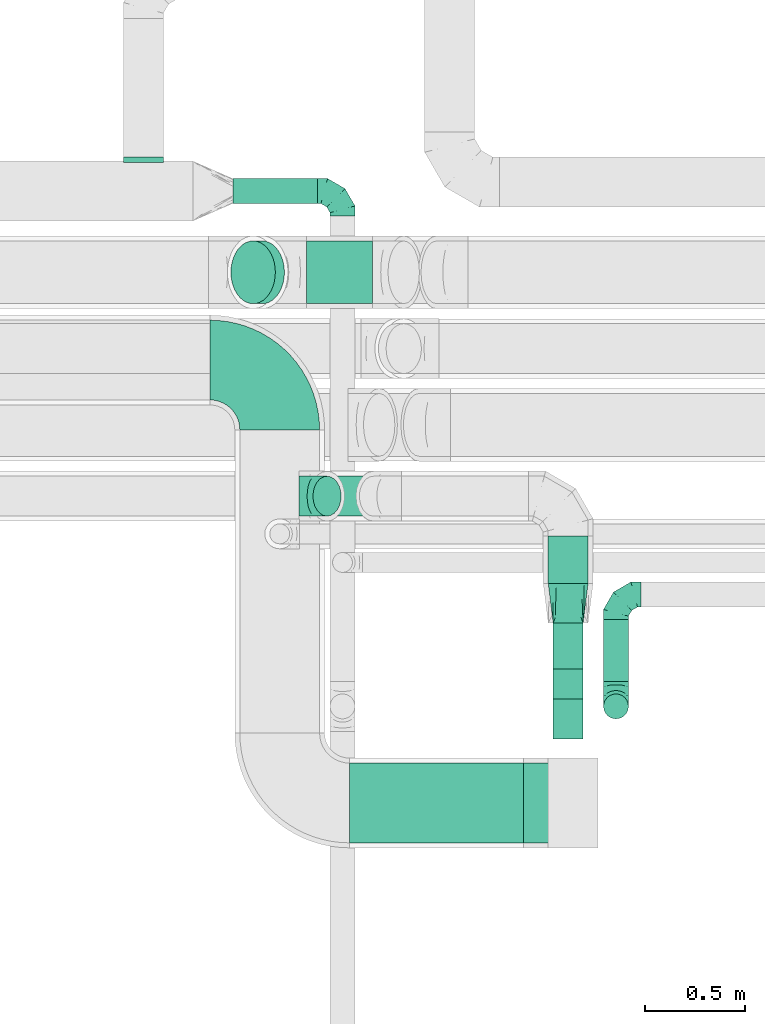
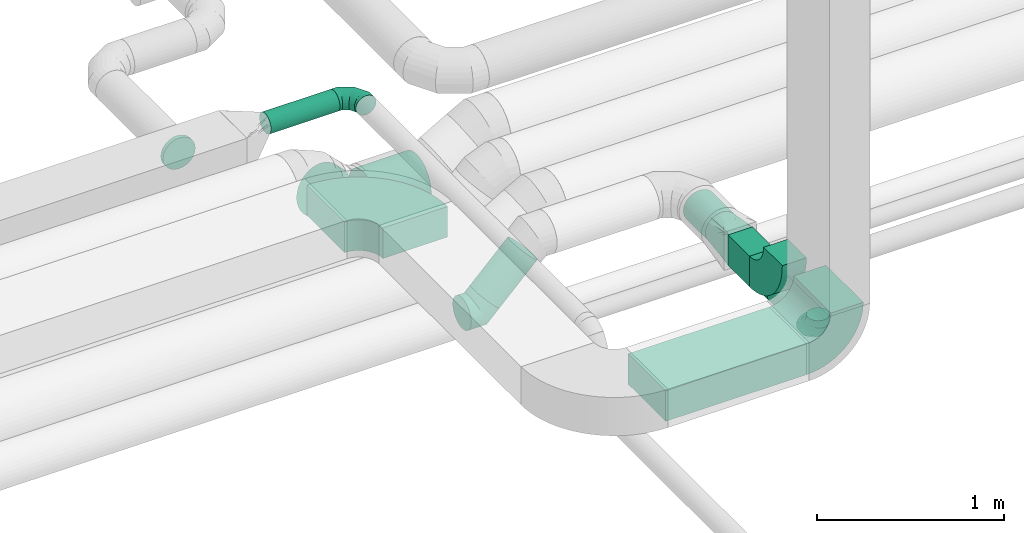
# One storey, part 63 of 92: 9 flow fittings, 8 flow segments.
"""IFC2X3 building model written with IfcOpenShell, lengths in millimetres."""

import ifcopenshell
import ifcopenshell.guid

model = None  # the IFC model being written
_history = None  # IfcOwnerHistory: only IFC2X3 demands one
_inside = {}  # id of a spatial element -> (the spatial element, [elements in it])
_under = {}  # id of a project, library or spatial element -> (it, [spatial elements below it])
_declared = {}  # id of a project -> (the project, [libraries it declares])
_typed = {}  # id of a type object -> (the type object, [elements of that type])
_made_of = {}  # id of a material, layer set ... -> (it, [elements and type objects made of it])


def new_model(schema):
    """Start an empty IFC model of exactly this schema.

    Asked for "IFC4X3", IfcOpenShell would pick the latest addendum, in which some entities
    have other attributes; the version numbers below select the first issue.
    IFC2X3 requires an IfcOwnerHistory on every rooted entity: one is made here for all.
    """
    global model, _history
    if schema == "IFC4X3":
        model = ifcopenshell.file(schema_version=(4, 3, 0, 0))
    else:
        model = ifcopenshell.file(schema=schema)
    _inside.clear()
    _under.clear()
    _declared.clear()
    _typed.clear()
    _made_of.clear()
    _history = None
    if model.schema == "IFC2X3":
        org = make("IfcOrganization", Name="unknown")
        user = make(
            "IfcPersonAndOrganization",
            ThePerson=make("IfcPerson", FamilyName="unknown"),
            TheOrganization=org,
        )
        app = make(
            "IfcApplication",
            ApplicationDeveloper=org,
            Version="unknown",
            ApplicationFullName="unknown",
            ApplicationIdentifier="unknown",
        )
        _history = make(
            "IfcOwnerHistory",
            OwningUser=user,
            OwningApplication=app,
            ChangeAction="ADDED",
            CreationDate=0,
        )
    return model


def make(cls, **values):
    """One entity of the class cls with the attributes given. An attribute that is None is left unset."""
    return model.create_entity(
        cls, **{name: value for name, value in values.items() if value is not None}
    )


def entity(cls, *values):
    """Any entity or typed value of the class cls, its attributes in the order of the schema. None: left unset."""
    e = model.create_entity(cls)
    for i, value in enumerate(values):
        if value is not None:
            e[i] = value
    return e


def rooted(cls, **values):
    """An entity with a GlobalId (a new one), such as an element, a storey or a relation."""
    return make(cls, GlobalId=ifcopenshell.guid.new(), OwnerHistory=_history, **values)


def si_unit(unit_type, name, prefix=None):
    """IfcSIUnit, for example si_unit("LENGTHUNIT", "METRE", prefix="MILLI")."""
    return make("IfcSIUnit", UnitType=unit_type, Prefix=prefix, Name=name)


def converted_unit(unit_type, name, factor, base, dimensions=None, offset=None):
    """IfcConversionBasedUnit, such as the inch: factor (a typed value) times the base unit."""
    return make(
        "IfcConversionBasedUnit"
        if offset is None
        else "IfcConversionBasedUnitWithOffset",
        ConversionOffset=offset,
        Dimensions=None
        if dimensions is None
        else entity("IfcDimensionalExponents", *dimensions),
        UnitType=unit_type,
        Name=name,
        ConversionFactor=make(
            "IfcMeasureWithUnit", ValueComponent=factor, UnitComponent=base
        ),
    )


def derived_unit(unit_type, elements):
    """IfcDerivedUnit: a product of units, each with its exponent."""
    return make(
        "IfcDerivedUnit",
        Elements=[
            make("IfcDerivedUnitElement", Unit=unit, Exponent=power)
            for unit, power in elements
        ],
        UnitType=unit_type,
    )


def assignment(units):
    """IfcUnitAssignment: the units of a project."""
    return None if units is None else make("IfcUnitAssignment", Units=units)


def point(xyz):
    """IfcCartesianPoint."""
    return None if xyz is None else make("IfcCartesianPoint", Coordinates=xyz)


def direction(xyz):
    """IfcDirection."""
    return None if xyz is None else make("IfcDirection", DirectionRatios=xyz)


def frame(location, z_axis=None, x_axis=None):
    """IfcAxis2Placement3D, a coordinate frame: its origin and axes. An axis left out is left unset."""
    return make(
        "IfcAxis2Placement3D",
        Location=point(location),
        Axis=direction(z_axis),
        RefDirection=direction(x_axis),
    )


def frame_2d(location, x_axis=None):
    """IfcAxis2Placement2D, a coordinate frame in the plane: its origin and x axis."""
    return make(
        "IfcAxis2Placement2D", Location=point(location), RefDirection=direction(x_axis)
    )


def origin():
    """The frame at (0, 0, 0) with its axes left unset."""
    return frame((0.0, 0.0, 0.0))


def origin_2d_with_axis():
    """The frame at (0, 0) in the plane with the x axis (1, 0) written out."""
    return frame_2d((0.0, 0.0), x_axis=(1.0, 0.0))


def place(relative_to, where):
    """IfcLocalPlacement: puts the frame where relative to a parent placement (None: the world)."""
    return make(
        "IfcLocalPlacement", PlacementRelTo=relative_to, RelativePlacement=where
    )


def context(
    kind, dimensions, precision=None, world=None, true_north=None, identifier=None
):
    """IfcGeometricRepresentationContext, for example the 3D "Model" context."""
    return make(
        "IfcGeometricRepresentationContext",
        ContextIdentifier=identifier,
        ContextType=kind,
        CoordinateSpaceDimension=dimensions,
        Precision=precision,
        WorldCoordinateSystem=world,
        TrueNorth=true_north,
    )


def subcontext(parent, identifier, kind, view, scale=None):
    """IfcGeometricRepresentationSubContext, for example "Body" below "Model"."""
    return make(
        "IfcGeometricRepresentationSubContext",
        ContextIdentifier=identifier,
        ContextType=kind,
        ParentContext=parent,
        TargetScale=scale,
        TargetView=view,
    )


def project(units=None, contexts=None):
    """IfcProject with its units and contexts."""
    return rooted(
        "IfcProject",
        Name="project",
        RepresentationContexts=contexts,
        UnitsInContext=assignment(units),
    )


def spatial(cls, under=None, at=None, **own):
    """A site, building, storey or space (cls), placed at a placement, below another one or the project."""
    s = rooted(cls, ObjectPlacement=at, **own)
    if under is not None:
        _under.setdefault(under.id(), (under, []))[1].append(s)
    return s


def polyline(points):
    """IfcPolyline through the points."""
    return make("IfcPolyline", Points=[point(p) for p in points])


def circle_curve(where, radius):
    """IfcCircle in the frame where."""
    return make("IfcCircle", Position=where, Radius=radius)


def parameter(value):
    """IfcParameterValue: where a trimmed curve begins or ends, as a parameter of its basis curve."""
    return model.create_entity("IfcParameterValue", value)


def trimmed(basis, trim1, trim2, sense, master):
    """IfcTrimmedCurve: the piece of a basis curve between two trims."""
    return make(
        "IfcTrimmedCurve",
        BasisCurve=basis,
        Trim1=trim1,
        Trim2=trim2,
        SenseAgreement=sense,
        MasterRepresentation=master,
    )


def segment(curve, same_sense, transition):
    """IfcCompositeCurveSegment."""
    return make(
        "IfcCompositeCurveSegment",
        Transition=transition,
        SameSense=same_sense,
        ParentCurve=curve,
    )


def composite_curve(segments, self_intersect=None):
    """IfcCompositeCurve: segments joined end to end."""
    return make("IfcCompositeCurve", Segments=segments, SelfIntersect=self_intersect)


def profile(cls, at=None, kind="AREA", **sizes):
    """A parametric profile (cls). Its sizes go by their IFC names, for example OverallWidth=200.0."""
    return make(cls, ProfileType=kind, Position=at, **sizes)


def rectangle(**sizes):
    """IfcRectangleProfileDef."""
    return profile("IfcRectangleProfileDef", **sizes)


def circle(**sizes):
    """IfcCircleProfileDef."""
    return profile("IfcCircleProfileDef", **sizes)


def outline(outer, holes=None, kind="AREA"):
    """IfcArbitraryClosedProfileDef: a profile drawn as a closed curve; with holes, ...WithVoids."""
    if holes is None:
        return make("IfcArbitraryClosedProfileDef", ProfileType=kind, OuterCurve=outer)
    return make(
        "IfcArbitraryProfileDefWithVoids",
        ProfileType=kind,
        OuterCurve=outer,
        InnerCurves=holes,
    )


def extrude(swept, where, along, depth):
    """IfcExtrudedAreaSolid: the profile swept, set in the frame where, extruded along a direction by depth."""
    return make(
        "IfcExtrudedAreaSolid",
        SweptArea=swept,
        Position=where,
        ExtrudedDirection=direction(along),
        Depth=depth,
    )


def faces_of(points, faces, orient=None, outer=None):
    """IfcFace entities. A face is a list of loops; a loop is a list of indices into points, from 0.

    orient and outer hold one flag for each loop. By default every Orientation is true, the
    first loop of a face is its IfcFaceOuterBound and the others are IfcFaceBound.
    """
    made = []
    for i, loops in enumerate(faces):
        bounds = []
        for j, loop in enumerate(loops):
            is_outer = j == 0 if outer is None else outer[i][j]
            bounds.append(
                make(
                    "IfcFaceOuterBound" if is_outer else "IfcFaceBound",
                    Bound=make("IfcPolyLoop", Polygon=[points[k] for k in loop]),
                    Orientation=True if orient is None else orient[i][j],
                )
            )
        made.append(make("IfcFace", Bounds=bounds))
    return made


def faceted_brep(points, faces, orient=None, outer=None, voids=None):
    """IfcFacetedBrep: a solid bounded by flat faces; with voids (closed shells), ...WithVoids."""
    shared = [point(p) for p in points]
    hull = make("IfcClosedShell", CfsFaces=faces_of(shared, faces, orient, outer))
    if voids is None:
        return make("IfcFacetedBrep", Outer=hull)
    return make(
        "IfcFacetedBrepWithVoids",
        Outer=hull,
        Voids=[
            make(cls, CfsFaces=faces_of(shared, fs, o, b)) for cls, fs, o, b in voids
        ],
    )


def shape(context_of_items, identifier, shape_type, items):
    """IfcShapeRepresentation: the items that make up one representation, for example the "Body"."""
    return make(
        "IfcShapeRepresentation",
        ContextOfItems=context_of_items,
        RepresentationIdentifier=identifier,
        RepresentationType=shape_type,
        Items=items,
    )


def source(mapping_origin, context_of_items, identifier, shape_type, items):
    """IfcRepresentationMap: a shape defined once, which mapped items show again and again."""
    return make(
        "IfcRepresentationMap",
        MappingOrigin=mapping_origin,
        MappedRepresentation=shape(context_of_items, identifier, shape_type, items),
    )


def transform(
    local_origin,
    x_axis=None,
    y_axis=None,
    z_axis=None,
    scale=None,
    scale2=None,
    scale3=None,
    uniform=True,
):
    """IfcCartesianTransformationOperator3D, or its non-uniform kind. x_axis, y_axis, z_axis: its Axis1, 2, 3."""
    if uniform:
        return make(
            "IfcCartesianTransformationOperator3D",
            Axis1=direction(x_axis),
            Axis2=direction(y_axis),
            LocalOrigin=point(local_origin),
            Scale=scale,
            Axis3=direction(z_axis),
        )
    return make(
        "IfcCartesianTransformationOperator3DnonUniform",
        Axis1=direction(x_axis),
        Axis2=direction(y_axis),
        LocalOrigin=point(local_origin),
        Scale=scale,
        Axis3=direction(z_axis),
        Scale2=scale2,
        Scale3=scale3,
    )


def mapped(mapping_source, mapping_target):
    """IfcMappedItem: shows the shape of a source again, moved by a transform."""
    return make(
        "IfcMappedItem", MappingSource=mapping_source, MappingTarget=mapping_target
    )


def material(Name=None, Category=None):
    """IfcMaterial."""
    return make("IfcMaterial", Name=Name, Category=Category)


def made_of(thing, what):
    """Note that an element or type object is made of a material, layer set ...; save() writes the relation."""
    if what is not None:
        _made_of.setdefault(what.id(), (what, []))[1].append(thing)
    return thing


def type_object(cls, material=None, **own):
    """A type object (cls), such as IfcWallType, which elements share."""
    return made_of(rooted(cls, **own), material)


def type_shapes(of_type, sources):
    """Give a type object the sources (RepresentationMaps) that its elements show as mapped items."""
    of_type.RepresentationMaps = sources


def element(
    cls,
    number,
    at=None,
    inside=None,
    cuts=None,
    type_object=None,
    material=None,
    context=None,
    identifier="Body",
    shape_type=None,
    held_by="IfcProductDefinitionShape",
    body=None,
    shapes=None,
    **own,
):
    """One element of the class cls, such as IfcWall. Its Tag is "e" and its number.

    at: its placement. inside: the storey or other place that contains it. cuts: it is an
    opening in that element (IfcRelVoidsElement). A single representation is given by context,
    identifier, shape_type and body (its items); several are given by shapes. held_by: the class
    of the entity that holds the representations. save() writes the other relations.
    """
    e = rooted(cls, Tag="e%d" % number, ObjectPlacement=at, **own)
    if body is not None:
        shapes = [shape(context, identifier, shape_type, body)]
    if shapes is not None:
        e.Representation = make(held_by, Representations=shapes)
    if inside is not None:
        _inside.setdefault(inside.id(), (inside, []))[1].append(e)
    if cuts is not None:
        rooted(
            "IfcRelVoidsElement", RelatingBuildingElement=cuts, RelatedOpeningElement=e
        )
    if type_object is not None:
        _typed.setdefault(type_object.id(), (type_object, []))[1].append(e)
    return made_of(e, material)


def aggregate(whole, parts):
    """IfcRelAggregates: a whole, such as a stair, and the parts it consists of."""
    return rooted("IfcRelAggregates", RelatingObject=whole, RelatedObjects=parts)


def save(model, path):
    """Write the relations noted so far, then the file.

    IfcRelAggregates (storeys below a building ...), IfcRelContainedInSpatialStructure (elements
    in a storey), IfcRelDefinesByType, IfcRelAssociatesMaterial and IfcRelDeclares: one each for
    every whole, place, type object, material and project.
    """
    for whole, parts in _under.values():
        aggregate(whole, parts)
    for where, things in _inside.values():
        rooted(
            "IfcRelContainedInSpatialStructure",
            RelatedElements=things,
            RelatingStructure=where,
        )
    for kind, things in _typed.values():
        rooted("IfcRelDefinesByType", RelatedObjects=things, RelatingType=kind)
    for what, things in _made_of.values():
        rooted("IfcRelAssociatesMaterial", RelatedObjects=things, RelatingMaterial=what)
    for by, libraries in _declared.values():
        rooted("IfcRelDeclares", RelatingContext=by, RelatedDefinitions=libraries)
    model.write(path)


model = new_model("IFC2X3")

# Units and contexts
model_context = context("Model", 3, precision=0.01, world=origin(), true_north=direction((6.12303176911189e-17, 1.0)))
body_context = subcontext(model_context, "Body", "Model", "MODEL_VIEW")
ifc_project = project(units=[si_unit("LENGTHUNIT", "METRE", prefix="MILLI"), si_unit("AREAUNIT", "SQUARE_METRE"), si_unit("VOLUMEUNIT", "CUBIC_METRE"), converted_unit("PLANEANGLEUNIT", "DEGREE", entity("IfcRatioMeasure", 0.0174532925199433), si_unit("PLANEANGLEUNIT", "RADIAN"), dimensions=[0, 0, 0, 0, 0, 0, 0]), si_unit("MASSUNIT", "GRAM", prefix="KILO"), derived_unit("MASSDENSITYUNIT", [(si_unit("MASSUNIT", "GRAM", prefix="KILO"), 1), (si_unit("LENGTHUNIT", "METRE"), -3)]), derived_unit("MOMENTOFINERTIAUNIT", [(si_unit("LENGTHUNIT", "METRE"), 4)]), si_unit("TIMEUNIT", "SECOND"), si_unit("FREQUENCYUNIT", "HERTZ"), si_unit("THERMODYNAMICTEMPERATUREUNIT", "DEGREE_CELSIUS"), derived_unit("THERMALTRANSMITTANCEUNIT", [(si_unit("MASSUNIT", "GRAM", prefix="KILO"), 1), (si_unit("THERMODYNAMICTEMPERATUREUNIT", "KELVIN"), -1), (si_unit("TIMEUNIT", "SECOND"), -3)]), derived_unit("VOLUMETRICFLOWRATEUNIT", [(si_unit("LENGTHUNIT", "METRE"), 3), (si_unit("TIMEUNIT", "SECOND"), -1)]), derived_unit("MASSFLOWRATEUNIT", [(si_unit("MASSUNIT", "GRAM", prefix="KILO"), 1), (si_unit("TIMEUNIT", "SECOND"), -1)]), derived_unit("ROTATIONALFREQUENCYUNIT", [(si_unit("TIMEUNIT", "SECOND"), -1)]), si_unit("ELECTRICCURRENTUNIT", "AMPERE"), si_unit("ELECTRICVOLTAGEUNIT", "VOLT"), si_unit("POWERUNIT", "WATT"), si_unit("FORCEUNIT", "NEWTON", prefix="KILO"), si_unit("ILLUMINANCEUNIT", "LUX"), si_unit("LUMINOUSFLUXUNIT", "LUMEN"), si_unit("LUMINOUSINTENSITYUNIT", "CANDELA"), derived_unit("USERDEFINED", [(si_unit("MASSUNIT", "GRAM", prefix="KILO"), -1), (si_unit("LENGTHUNIT", "METRE"), -2), (si_unit("TIMEUNIT", "SECOND"), 3), (si_unit("LUMINOUSFLUXUNIT", "LUMEN"), 1)]), derived_unit("LINEARVELOCITYUNIT", [(si_unit("LENGTHUNIT", "METRE"), 1), (si_unit("TIMEUNIT", "SECOND"), -1)]), si_unit("PRESSUREUNIT", "PASCAL"), derived_unit("USERDEFINED", [(si_unit("LENGTHUNIT", "METRE"), -2), (si_unit("MASSUNIT", "GRAM", prefix="KILO"), 1), (si_unit("TIMEUNIT", "SECOND"), -2)]), derived_unit("LINEARFORCEUNIT", [(si_unit("MASSUNIT", "GRAM", prefix="KILO"), 1), (si_unit("LENGTHUNIT", "METRE"), 1), (si_unit("TIMEUNIT", "SECOND"), -2), (si_unit("LENGTHUNIT", "METRE"), -1)]), derived_unit("PLANARFORCEUNIT", [(si_unit("MASSUNIT", "GRAM", prefix="KILO"), 1), (si_unit("LENGTHUNIT", "METRE"), 1), (si_unit("TIMEUNIT", "SECOND"), -2), (si_unit("LENGTHUNIT", "METRE"), -2)])], contexts=[model_context])

# Site, building, storey
site_placement = place(None, origin())
site = spatial("IfcSite", under=ifc_project, at=site_placement, CompositionType="ELEMENT")
building_placement = place(site_placement, origin())
building = spatial("IfcBuilding", under=site, at=building_placement, CompositionType="ELEMENT")
storey_placement = place(building_placement, frame((0.0, 0.0, 4200.0)))
storey = spatial("IfcBuildingStorey", under=building, at=storey_placement, CompositionType="ELEMENT", Elevation=4200.0)

# Flow segments
duct_segment_type_1 = type_object("IfcDuctSegmentType", PredefinedType="NOTDEFINED")
flow_segment_1_placement = place(storey_placement, frame((51691.52, 13732.59, 3250.0)))
element("IfcFlowSegment", 1, at=flow_segment_1_placement, inside=storey, type_object=duct_segment_type_1, context=body_context, shape_type="SweptSolid", body=[
    extrude(rectangle(XDim=229.879164448908, YDim=150.000000000001, at=origin_2d_with_axis()), frame((75.0, 114.94, 0.0), z_axis=(0.0, 0.0, 1.0), x_axis=(0.0, -1.0, 0.0)), (0.0, 0.0, 1.0), 200.0),
])
flow_segment_2_placement = place(storey_placement, frame((50670.11, 12861.01, 3257.5)))
element("IfcFlowSegment", 2, at=flow_segment_2_placement, inside=storey, type_object=duct_segment_type_1, context=body_context, shape_type="SweptSolid", body=[
    extrude(rectangle(XDim=871.252251145747, YDim=400.0, at=origin_2d_with_axis()), frame((435.63, 200.0, 0.0)), (0.0, 0.0, 1.0), 200.0),
])
duct_segment_type_2 = type_object("IfcDuctSegmentType", PredefinedType="NOTDEFINED")
flow_segment_3_placement = place(storey_placement, frame((51942.31, 13670.35, 2885.9)))
element("IfcFlowSegment", 3, at=flow_segment_3_placement, inside=storey, type_object=duct_segment_type_2, context=body_context, shape_type="SweptSolid", body=[
    extrude(circle(Radius=62.5, at=origin_2d_with_axis()), frame((64.1, 0.0, 64.1), z_axis=(0.0, 1.0, 0.0), x_axis=(-1.0, 0.0, 0.0)), (0.0, 0.0, 1.0), 310.938126390633),
])
flow_segment_4_placement = place(storey_placement, frame((51664.92, 14162.47, 3248.4)))
element("IfcFlowSegment", 4, at=flow_segment_4_placement, inside=storey, type_object=duct_segment_type_2, context=body_context, shape_type="SweptSolid", body=[
    extrude(circle(Radius=100.0, at=origin_2d_with_axis()), frame((101.6, 0.0, 101.6), z_axis=(0.0, 1.0, 0.0), x_axis=(1.0, 0.0, 0.0)), (0.0, 0.0, 1.0), 237.02849690736),
])
flow_segment_5_placement = place(storey_placement, frame((50085.0, 16065.42, 3363.4)))
element("IfcFlowSegment", 5, at=flow_segment_5_placement, inside=storey, type_object=duct_segment_type_2, context=body_context, shape_type="SweptSolid", body=[
    extrude(circle(Radius=62.5, at=origin_2d_with_axis()), frame((0.0, 64.1, 64.1), z_axis=(1.0, 0.0, 0.0), x_axis=(0.0, 1.0, 0.0)), (0.0, 0.0, 1.0), 425.000000000033),
])
flow_segment_6_placement = place(storey_placement, frame((50485.19, 14497.9, 2986.27)))
element("IfcFlowSegment", 6, at=flow_segment_6_placement, inside=storey, type_object=duct_segment_type_2, context=body_context, shape_type="SweptSolid", body=[
    extrude(circle(Radius=100.0, at=origin_2d_with_axis()), frame((72.31, 101.6, 72.31), z_axis=(0.707106781186534, 0.0, 0.707106781186561), x_axis=(0.0, 1.0, 0.0)), (0.0, 0.0, 1.0), 329.289321881358),
])
duct_segment_type_3 = type_object("IfcDuctSegmentType", PredefinedType="NOTDEFINED")
flow_segment_7_placement = place(storey_placement, frame((50455.12, 15562.91, 2910.9)))
element("IfcFlowSegment", 7, at=flow_segment_7_placement, inside=storey, type_object=duct_segment_type_3, context=body_context, shape_type="SweptSolid", body=[
    extrude(circle(Radius=157.5, at=origin_2d_with_axis()), frame((0.0, 159.1, 159.1), z_axis=(1.0, 0.0, 0.0), x_axis=(0.0, -1.0, 0.0)), (0.0, 0.0, 1.0), 329.349692166482),
])
flow_segment_8_placement = place(storey_placement, frame((50073.94, 15562.91, 3049.3)))
element("IfcFlowSegment", 8, at=flow_segment_8_placement, inside=storey, type_object=duct_segment_type_3, context=body_context, shape_type="SweptSolid", body=[
    extrude(circle(Radius=157.5, at=origin_2d_with_axis()), frame((112.96, 159.1, 158.44), z_axis=(0.707106698793161, 0.0, -0.707106863579924), x_axis=(0.0, -1.0, 0.0)), (0.0, 0.0, 1.0), 64.3144941480328),
])

# Flow fittings
ifc_material = material()
duct_fitting_type_1 = type_object("IfcDuctFittingType", PredefinedType="NOTDEFINED", material=ifc_material)
shared_shape_1 = source(origin(), body_context, "Body", "Brep", [
    faceted_brep([(-125.0, 0.0, -62.5), (-125.0, -16.18, -60.37), (-125.0, -31.25, -54.13), (-125.0, -44.19, -44.19), (-125.0, -54.13, -31.25), (-125.0, -60.37, -16.18), (-125.0, -62.5, 0.0), (-125.0, -60.37, 16.18), (-125.0, -54.13, 31.25), (-125.0, -44.19, 44.19), (-125.0, -31.25, 54.13), (-125.0, -16.18, 60.37), (-125.0, 0.0, 62.5), (-125.0, 16.18, 60.37), (-125.0, 31.25, 54.13), (-125.0, 44.19, 44.19), (-125.0, 54.13, 31.25), (-125.0, 60.37, 16.18), (-125.0, 62.5, 0.0), (-125.0, 60.37, -16.18), (-125.0, 54.13, -31.25), (-125.0, 44.19, -44.19), (-125.0, 31.25, -54.13), (-125.0, 16.18, -60.37), (-95.84, 16.18, 60.37), (-99.88, 31.25, 54.13), (-91.51, 0.0, 62.5), (-103.35, 44.19, 44.19), (-107.68, 60.37, 16.18), (-108.25, 62.5, 0.0), (-106.01, 54.13, 31.25), (-106.01, 54.13, -31.25), (-103.35, 44.19, -44.19), (-107.68, 60.37, -16.18), (-95.84, 16.18, -60.37), (-91.51, 0.0, -62.5), (-99.88, 31.25, -54.13), (-87.17, -16.18, -60.37), (-83.13, -31.25, -54.13), (-79.66, -44.19, -44.19), (-77.0, -54.13, -31.25), (-75.33, -60.37, -16.18), (-74.76, -62.5, 0.0), (-75.33, -60.37, 16.18), (-77.0, -54.13, 31.25), (-79.66, -44.19, 44.19), (-83.13, -31.25, 54.13), (-87.17, -16.18, 60.37), (-45.34, 45.34, 60.37), (-56.37, 56.37, 54.13), (-33.49, 33.49, 62.5), (-65.85, 65.85, 44.19), (-73.12, 73.12, 31.25), (-77.69, 77.69, 16.18), (-79.25, 79.25, 0.0), (-77.69, 77.69, -16.18), (-73.12, 73.12, -31.25), (-65.85, 65.85, -44.19), (-45.34, 45.34, -60.37), (-33.49, 33.49, -62.5), (-56.37, 56.37, -54.13), (-21.65, 21.65, -60.37), (-10.62, 10.62, -54.13), (-1.14, 1.14, -44.19), (6.13, -6.13, -31.25), (10.7, -10.7, -16.18), (12.26, -12.26, 0.0), (10.7, -10.7, 16.18), (6.13, -6.13, 31.25), (-1.14, 1.14, 44.19), (-10.62, 10.62, 54.13), (-21.65, 21.65, 60.37), (-16.18, 95.84, 60.37), (-31.25, 99.88, 54.13), (0.0, 91.51, 62.5), (-44.19, 103.35, 44.19), (-54.13, 106.01, 31.25), (-60.37, 107.68, 16.18), (-62.5, 108.25, 0.0), (-60.37, 107.68, -16.18), (-54.13, 106.01, -31.25), (-44.19, 103.35, -44.19), (-16.18, 95.84, -60.37), (0.0, 91.51, -62.5), (-31.25, 99.88, -54.13), (16.18, 87.17, -60.37), (31.25, 83.13, -54.13), (44.19, 79.66, -44.19), (54.13, 77.0, -31.25), (60.37, 75.33, -16.18), (62.5, 74.76, 0.0), (60.37, 75.33, 16.18), (54.13, 77.0, 31.25), (44.19, 79.66, 44.19), (31.25, 83.13, 54.13), (16.18, 87.17, 60.37), (-16.18, 125.0, -60.37), (-31.25, 125.0, -54.13), (-44.19, 125.0, -44.19), (-54.13, 125.0, -31.25), (-60.37, 125.0, -16.18), (-62.5, 125.0, 0.0), (-60.37, 125.0, 16.18), (-54.13, 125.0, 31.25), (-44.19, 125.0, 44.19), (-31.25, 125.0, 54.13), (-16.18, 125.0, 60.37), (0.0, 125.0, 62.5), (16.18, 125.0, 60.37), (31.25, 125.0, 54.13), (44.19, 125.0, 44.19), (54.13, 125.0, 31.25), (60.37, 125.0, 16.18), (62.5, 125.0, 0.0), (60.37, 125.0, -16.18), (54.13, 125.0, -31.25), (44.19, 125.0, -44.19), (31.25, 125.0, -54.13), (16.18, 125.0, -60.37), (0.0, 125.0, -62.5)], [[[0, 1, 2, 3, 4, 5, 6, 7, 8, 9, 10, 11, 12, 13, 14, 15, 16, 17, 18, 19, 20, 21, 22, 23]], [[24, 25, 14, 13]], [[26, 24, 13, 12]], [[14, 25, 27, 15]], [[28, 29, 18, 17]], [[30, 28, 17, 16]], [[15, 27, 30, 16]], [[20, 31, 32, 21]], [[33, 31, 20, 19]], [[18, 29, 33, 19]], [[34, 35, 0, 23]], [[36, 34, 23, 22]], [[21, 32, 36, 22]], [[1, 0, 35, 37]], [[2, 1, 37, 38]], [[38, 39, 3, 2]], [[5, 4, 40, 41]], [[6, 5, 41, 42]], [[39, 40, 4, 3]], [[6, 42, 43, 7]], [[7, 43, 44, 8]], [[45, 9, 8, 44]], [[9, 45, 46, 10]], [[10, 46, 47, 11]], [[26, 12, 11, 47]], [[48, 49, 25, 24]], [[50, 48, 24, 26]], [[27, 25, 49, 51]], [[52, 53, 28, 30]], [[51, 52, 30, 27]], [[29, 28, 53, 54]], [[55, 56, 31, 33]], [[54, 55, 33, 29]], [[57, 32, 31, 56]], [[58, 59, 35, 34]], [[60, 58, 34, 36]], [[57, 60, 36, 32]], [[37, 35, 59, 61]], [[38, 37, 61, 62]], [[39, 38, 62, 63]], [[41, 40, 64, 65]], [[42, 41, 65, 66]], [[63, 64, 40, 39]], [[43, 42, 66, 67]], [[44, 43, 67, 68]], [[68, 69, 45, 44]], [[46, 45, 69, 70]], [[47, 46, 70, 71]], [[26, 47, 71, 50]], [[72, 73, 49, 48]], [[74, 72, 48, 50]], [[51, 49, 73, 75]], [[76, 77, 53, 52]], [[75, 76, 52, 51]], [[54, 53, 77, 78]], [[79, 80, 56, 55]], [[78, 79, 55, 54]], [[81, 57, 56, 80]], [[82, 83, 59, 58]], [[84, 82, 58, 60]], [[81, 84, 60, 57]], [[61, 59, 83, 85]], [[62, 61, 85, 86]], [[63, 62, 86, 87]], [[65, 64, 88, 89]], [[66, 65, 89, 90]], [[87, 88, 64, 63]], [[67, 66, 90, 91]], [[68, 67, 91, 92]], [[92, 93, 69, 68]], [[70, 69, 93, 94]], [[71, 70, 94, 95]], [[50, 71, 95, 74]], [[96, 97, 98, 99, 100, 101, 102, 103, 104, 105, 106, 107, 108, 109, 110, 111, 112, 113, 114, 115, 116, 117, 118, 119]], [[72, 74, 107, 106]], [[73, 72, 106, 105]], [[75, 73, 105, 104]], [[77, 76, 103, 102]], [[78, 77, 102, 101]], [[75, 104, 103, 76]], [[78, 101, 100, 79]], [[79, 100, 99, 80]], [[80, 99, 98, 81]], [[96, 119, 83, 82]], [[97, 96, 82, 84]], [[84, 81, 98, 97]], [[83, 119, 118, 85]], [[85, 118, 117, 86]], [[116, 87, 86, 117]], [[88, 115, 114, 89]], [[89, 114, 113, 90]], [[115, 88, 87, 116]], [[91, 90, 113, 112]], [[92, 91, 112, 111]], [[111, 110, 93, 92]], [[95, 94, 109, 108]], [[74, 95, 108, 107]], [[110, 109, 94, 93]]]),
])
type_shapes(duct_fitting_type_1, [shared_shape_1])
for number, where, z_axis, x_axis in (
    (9, (52006.4, 14106.28, 2950.0), (0.0, 0.0, 1.0), (-1.0, 0.0, 0.0)),
    (10, (50635.0, 16129.51, 3427.5), (0.0, 0.0, 1.0), (0.0, 1.0, 0.0)),
    (11, (52006.4, 13545.35, 2950.0), (-1.0, 0.0, -4.73472033876912e-08), (0.0, -1.0, 0.0)),
):
    element("IfcFlowFitting", number, at=place(storey_placement, frame(where, z_axis=z_axis, x_axis=x_axis)), inside=storey, type_object=duct_fitting_type_1, material=ifc_material, context=body_context, shape_type="MappedRepresentation", body=[
        mapped(shared_shape_1, transform((0.0, 0.0, 0.0), scale=1.0)),
    ])
duct_fitting_type_2 = type_object("IfcDuctFittingType", PredefinedType="NOTDEFINED", material=ifc_material)
shared_shape_2 = source(origin(), body_context, "Body", "Brep", [
    faceted_brep([(200.0, 30.9, 95.11), (200.0, 19.08, 96.98), (200.0, 9.54, 98.49), (200.0, 4.77, 99.24), (200.0, 0.0, 100.0), (200.0, -4.77, 99.24), (200.0, -9.54, 98.49), (200.0, -19.08, 96.98), (200.0, -30.9, 95.11), (200.0, -44.84, 88.0), (200.0, -58.78, 80.9), (200.0, -69.84, 69.84), (200.0, -80.9, 58.78), (200.0, -88.0, 44.84), (200.0, -95.11, 30.9), (200.0, -96.98, 19.08), (200.0, -98.49, 9.54), (200.0, -99.24, 4.77), (200.0, -100.0, 0.0), (200.0, -99.24, -4.77), (200.0, -98.49, -9.54), (200.0, -96.98, -19.08), (200.0, -95.11, -30.9), (200.0, -88.0, -44.84), (200.0, -80.9, -58.78), (200.0, -69.84, -69.84), (200.0, -58.78, -80.9), (200.0, -44.84, -88.0), (200.0, -30.9, -95.11), (200.0, -19.08, -96.98), (200.0, -9.54, -98.49), (200.0, -4.77, -99.24), (200.0, 0.0, -100.0), (200.0, 4.77, -99.24), (200.0, 9.54, -98.49), (200.0, 19.08, -96.98), (200.0, 30.9, -95.11), (200.0, 44.84, -88.0), (200.0, 58.78, -80.9), (200.0, 69.84, -69.84), (200.0, 80.9, -58.78), (200.0, 88.0, -44.84), (200.0, 95.11, -30.9), (200.0, 96.98, -19.08), (200.0, 98.49, -9.54), (200.0, 99.24, -4.77), (200.0, 100.0, 0.0), (200.0, 99.24, 4.77), (200.0, 98.49, 9.54), (200.0, 96.98, 19.08), (200.0, 95.11, 30.9), (200.0, 88.0, 44.84), (200.0, 80.9, 58.78), (200.0, 69.84, 69.84), (200.0, 58.78, 80.9), (200.0, 44.84, 88.0), (0.0, -75.0, 100.0), (0.0, 75.0, 100.0), (0.0, 75.0, -100.0), (0.0, -75.0, -100.0), (104.11, -35.96, 100.0), (100.0, -70.65, 87.43), (26.03, -65.24, 100.0), (78.09, -45.72, 100.0), (52.06, -55.48, 100.0), (188.01, -4.49, 100.0), (176.03, -8.99, 100.0), (152.06, -17.98, 100.0), (128.09, -26.97, 100.0), (52.06, -81.51, 73.97), (78.09, -84.76, 60.96), (104.11, -88.01, 47.94), (128.09, -91.01, 35.96), (152.06, -94.01, 23.97), (176.03, -97.0, 11.99), (188.01, -98.5, 5.99), (26.03, -78.25, 86.99), (26.03, -78.25, -86.99), (52.06, -81.51, -73.97), (78.09, -84.76, -60.96), (104.11, -88.01, -47.94), (128.09, -91.01, -35.96), (152.06, -94.01, -23.97), (176.03, -97.0, -11.99), (188.01, -98.5, -5.99), (100.0, -74.93, -83.15), (52.06, -55.48, -100.0), (78.09, -45.72, -100.0), (104.11, -35.96, -100.0), (128.09, -26.97, -100.0), (152.06, -17.98, -100.0), (176.03, -8.99, -100.0), (188.01, -4.49, -100.0), (26.03, -65.24, -100.0), (26.03, 65.24, -100.0), (52.06, 55.48, -100.0), (78.09, 45.72, -100.0), (104.11, 35.96, -100.0), (128.09, 26.97, -100.0), (152.06, 17.98, -100.0), (176.03, 8.99, -100.0), (188.01, 4.49, -100.0), (100.0, 70.65, -87.43), (52.06, 81.51, -73.97), (78.09, 84.76, -60.96), (104.11, 88.01, -47.94), (128.09, 91.01, -35.96), (152.06, 94.01, -23.97), (176.03, 97.0, -11.99), (188.01, 98.5, -5.99), (26.03, 78.25, -86.99), (26.03, 78.25, 86.99), (52.06, 81.51, 73.97), (78.09, 84.76, 60.96), (104.11, 88.01, 47.94), (128.09, 91.01, 35.96), (152.06, 94.01, 23.97), (176.03, 97.0, 11.99), (188.01, 98.5, 5.99), (100.0, 74.93, 83.15), (52.06, 55.48, 100.0), (78.09, 45.72, 100.0), (104.11, 35.96, 100.0), (128.09, 26.97, 100.0), (152.06, 17.98, 100.0), (176.03, 8.99, 100.0), (188.01, 4.49, 100.0), (26.03, 65.24, 100.0)], [[[0, 1, 2, 3, 4, 5, 6, 7, 8, 9, 10, 11, 12, 13, 14, 15, 16, 17, 18, 19, 20, 21, 22, 23, 24, 25, 26, 27, 28, 29, 30, 31, 32, 33, 34, 35, 36, 37, 38, 39, 40, 41, 42, 43, 44, 45, 46, 47, 48, 49, 50, 51, 52, 53, 54, 55]], [[56, 57, 58, 59]], [[60, 9, 8]], [[56, 61, 62]], [[9, 60, 63, 64]], [[65, 66, 67, 68, 60, 8, 7, 6, 5, 4]], [[62, 61, 10]], [[13, 69, 70, 71]], [[64, 10, 9]], [[14, 71, 72, 73, 74, 75, 18, 17, 16, 15]], [[12, 76, 69]], [[71, 14, 13]], [[61, 76, 11]], [[10, 64, 62]], [[76, 12, 11]], [[10, 61, 11]], [[61, 56, 76]], [[69, 13, 12]], [[75, 74, 73, 72, 71, 70, 69, 76, 56, 59, 77, 78, 79, 80, 81, 82, 83, 84, 18]], [[80, 23, 22]], [[59, 85, 77]], [[23, 80, 79, 78]], [[84, 83, 82, 81, 80, 22, 21, 20, 19, 18]], [[77, 85, 24]], [[27, 86, 87, 88]], [[78, 24, 23]], [[28, 88, 89, 90, 91, 92, 32, 31, 30, 29]], [[26, 93, 86]], [[88, 28, 27]], [[85, 93, 25]], [[24, 78, 77]], [[93, 26, 25]], [[24, 85, 25]], [[85, 59, 93]], [[86, 27, 26]], [[92, 91, 90, 89, 88, 87, 86, 93, 59, 58, 94, 95, 96, 97, 98, 99, 100, 101, 32]], [[97, 37, 36]], [[58, 102, 94]], [[37, 97, 96, 95]], [[101, 100, 99, 98, 97, 36, 35, 34, 33, 32]], [[94, 102, 38]], [[41, 103, 104, 105]], [[95, 38, 37]], [[42, 105, 106, 107, 108, 109, 46, 45, 44, 43]], [[40, 110, 103]], [[105, 42, 41]], [[102, 110, 39]], [[38, 95, 94]], [[110, 40, 39]], [[38, 102, 39]], [[102, 58, 110]], [[103, 41, 40]], [[58, 57, 111, 112, 113, 114, 115, 116, 117, 118, 46, 109, 108, 107, 106, 105, 104, 103, 110]], [[114, 51, 50]], [[57, 119, 111]], [[51, 114, 113, 112]], [[118, 117, 116, 115, 114, 50, 49, 48, 47, 46]], [[111, 119, 52]], [[55, 120, 121, 122]], [[112, 52, 51]], [[0, 122, 123, 124, 125, 126, 4, 3, 2, 1]], [[54, 127, 120]], [[122, 0, 55]], [[119, 127, 53]], [[52, 112, 111]], [[127, 54, 53]], [[52, 119, 53]], [[119, 57, 127]], [[120, 55, 54]], [[57, 56, 62, 64, 63, 60, 68, 67, 66, 65, 4, 126, 125, 124, 123, 122, 121, 120, 127]]]),
])
type_shapes(duct_fitting_type_2, [shared_shape_2])
flow_fitting_1_placement = place(storey_placement, frame((51766.52, 13962.47, 3350.0), z_axis=(0.0, 0.0, 1.0), x_axis=(0.0, 1.0, 0.0)))
element("IfcFlowFitting", 12, at=flow_fitting_1_placement, inside=storey, type_object=duct_fitting_type_2, material=ifc_material, context=body_context, shape_type="MappedRepresentation", body=[
    mapped(shared_shape_2, transform((0.0, 0.0, 0.0), scale=1.0)),
])
duct_fitting_type_3 = type_object("IfcDuctFittingType", PredefinedType="NOTDEFINED", material=ifc_material)
shared_shape_3 = source(origin(), body_context, "Body", "Brep", [
    faceted_brep([(-82.84, 0.0, -100.0), (-82.84, -25.88, -96.59), (-82.84, -50.0, -86.6), (-82.84, -70.71, -70.71), (-82.84, -86.6, -50.0), (-82.84, -96.59, -25.88), (-82.84, -100.0, 0.0), (-82.84, -96.59, 25.88), (-82.84, -86.6, 50.0), (-82.84, -70.71, 70.71), (-82.84, -50.0, 86.6), (-82.84, -25.88, 96.59), (-82.84, 0.0, 100.0), (-82.84, 25.88, 96.59), (-82.84, 50.0, 86.6), (-82.84, 70.71, 70.71), (-82.84, 86.6, 50.0), (-82.84, 96.59, 25.88), (-82.84, 100.0, 0.0), (-82.84, 96.59, -25.88), (-82.84, 86.6, -50.0), (-82.84, 70.71, -70.71), (-82.84, 50.0, -86.6), (-82.84, 25.88, -96.59), (-10.72, 25.88, 96.59), (-20.71, 50.0, 86.6), (0.0, 0.0, 100.0), (-29.29, 70.71, 70.71), (-35.87, 86.6, 50.0), (-40.01, 96.59, 25.88), (-41.42, 100.0, 0.0), (-40.01, 96.59, -25.88), (-35.87, 86.6, -50.0), (-29.29, 70.71, -70.71), (-10.72, 25.88, -96.59), (0.0, 0.0, -100.0), (-20.71, 50.0, -86.6), (10.72, -25.88, -96.59), (20.71, -50.0, -86.6), (29.29, -70.71, -70.71), (35.87, -86.6, -50.0), (40.01, -96.59, -25.88), (41.42, -100.0, 0.0), (40.01, -96.59, 25.88), (35.87, -86.6, 50.0), (29.29, -70.71, 70.71), (20.71, -50.0, 86.6), (10.72, -25.88, 96.59), (58.58, 58.58, 100.0), (40.28, 76.88, 96.59), (23.22, 93.93, 86.6), (8.58, 108.58, 70.71), (-2.66, 119.82, 50.0), (-9.72, 126.88, 25.88), (-12.13, 129.29, 0.0), (-9.72, 126.88, -25.88), (-2.66, 119.82, -50.0), (8.58, 108.58, -70.71), (23.22, 93.93, -86.6), (40.28, 76.88, -96.59), (58.58, 58.58, -100.0), (76.88, 40.28, -96.59), (93.93, 23.22, -86.6), (108.58, 8.58, -70.71), (119.82, -2.66, -50.0), (126.88, -9.72, -25.88), (129.29, -12.13, 0.0), (126.88, -9.72, 25.88), (119.82, -2.66, 50.0), (108.58, 8.58, 70.71), (93.93, 23.22, 86.6), (76.88, 40.28, 96.59)], [[[0, 1, 2, 3, 4, 5, 6, 7, 8, 9, 10, 11, 12, 13, 14, 15, 16, 17, 18, 19, 20, 21, 22, 23]], [[24, 25, 14, 13]], [[26, 24, 13, 12]], [[14, 25, 27, 15]], [[28, 29, 17, 16]], [[28, 16, 15, 27]], [[30, 18, 17, 29]], [[31, 32, 20, 19]], [[30, 31, 19, 18]], [[32, 33, 21, 20]], [[34, 35, 0, 23]], [[36, 34, 23, 22]], [[33, 36, 22, 21]], [[1, 0, 35, 37]], [[2, 1, 37, 38]], [[38, 39, 3, 2]], [[5, 4, 40, 41]], [[6, 5, 41, 42]], [[39, 40, 4, 3]], [[6, 42, 43, 7]], [[7, 43, 44, 8]], [[8, 44, 45, 9]], [[9, 45, 46, 10]], [[10, 46, 47, 11]], [[26, 12, 11, 47]], [[24, 26, 48, 49]], [[25, 24, 49, 50]], [[27, 25, 50, 51]], [[29, 28, 52, 53]], [[30, 29, 53, 54]], [[51, 52, 28, 27]], [[30, 54, 55, 31]], [[31, 55, 56, 32]], [[57, 33, 32, 56]], [[36, 58, 59, 34]], [[34, 59, 60, 35]], [[58, 36, 33, 57]], [[35, 60, 61, 37]], [[37, 61, 62, 38]], [[63, 39, 38, 62]], [[40, 64, 65, 41]], [[41, 65, 66, 42]], [[64, 40, 39, 63]], [[43, 42, 66, 67]], [[44, 43, 67, 68]], [[68, 69, 45, 44]], [[47, 46, 70, 71]], [[26, 47, 71, 48]], [[69, 70, 46, 45]], [[59, 58, 57, 56, 55, 54, 53, 52, 51, 50, 49, 48, 71, 70, 69, 68, 67, 66, 65, 64, 63, 62, 61, 60]]]),
])
type_shapes(duct_fitting_type_3, [shared_shape_3])
flow_fitting_2_placement = place(storey_placement, frame((50498.92, 14599.5, 3000.0), z_axis=(0.0, 1.0, 0.0), x_axis=(-0.707106781186534, 0.0, -0.707106781186561)))
element("IfcFlowFitting", 13, at=flow_fitting_2_placement, inside=storey, type_object=duct_fitting_type_3, material=ifc_material, context=body_context, shape_type="MappedRepresentation", body=[
    mapped(shared_shape_3, transform((0.0, 0.0, 0.0), scale=1.0)),
])
duct_fitting_type_4 = type_object("IfcDuctFittingType", PredefinedType="NOTDEFINED", material=ifc_material)
shared_shape_4 = source(origin(), body_context, "Body", "Brep", [
    faceted_brep([(20.0, 25.88, -96.59), (20.0, 50.0, -86.6), (20.0, 70.71, -70.71), (20.0, 86.6, -50.0), (20.0, 96.59, -25.88), (20.0, 100.0, 0.0), (20.0, 96.59, 25.88), (20.0, 86.6, 50.0), (20.0, 70.71, 70.71), (20.0, 50.0, 86.6), (20.0, 25.88, 96.59), (20.0, 0.0, 100.0), (20.0, -25.88, 96.59), (20.0, -50.0, 86.6), (20.0, -70.71, 70.71), (20.0, -86.6, 50.0), (20.0, -96.59, 25.88), (20.0, -100.0, 0.0), (20.0, -96.59, -25.88), (20.0, -86.6, -50.0), (20.0, -70.71, -70.71), (20.0, -50.0, -86.6), (20.0, -25.88, -96.59), (20.0, 0.0, -100.0), (0.0, 0.0, 100.0), (0.0, 25.88, 96.59), (-6.1, 25.88, 96.59), (-6.1, 0.0, 100.0), (0.0, 50.0, 86.6), (-6.1, 50.0, 86.6), (0.0, 70.71, 70.71), (-6.1, 70.71, 70.71), (0.0, 86.6, 50.0), (0.0, 96.59, 25.88), (-6.1, 96.59, 25.88), (-6.1, 86.6, 50.0), (0.0, 100.0, 0.0), (-6.1, 100.0, 0.0), (0.0, 96.59, -25.88), (-6.1, 96.59, -25.88), (0.0, 86.6, -50.0), (-6.1, 86.6, -50.0), (0.0, 70.71, -70.71), (-6.1, 70.71, -70.71), (0.0, 50.0, -86.6), (0.0, 25.88, -96.59), (-6.1, 25.88, -96.59), (-6.1, 50.0, -86.6), (0.0, 0.0, -100.0), (-6.1, 0.0, -100.0), (0.0, -25.88, -96.59), (-6.1, -25.88, -96.59), (0.0, -50.0, -86.6), (-6.1, -50.0, -86.6), (0.0, -70.71, -70.71), (-6.1, -70.71, -70.71), (0.0, -86.6, -50.0), (0.0, -96.59, -25.88), (-6.1, -96.59, -25.88), (-6.1, -86.6, -50.0), (0.0, -100.0, 0.0), (-6.1, -100.0, 0.0), (0.0, -96.59, 25.88), (-6.1, -96.59, 25.88), (0.0, -86.6, 50.0), (-6.1, -86.6, 50.0), (0.0, -70.71, 70.71), (-6.1, -70.71, 70.71), (0.0, -50.0, 86.6), (0.0, -25.88, 96.59), (-6.1, -25.88, 96.59), (-6.1, -50.0, 86.6)], [[[0, 1, 2, 3, 4, 5, 6, 7, 8, 9, 10, 11, 12, 13, 14, 15, 16, 17, 18, 19, 20, 21, 22, 23]], [[24, 11, 10, 25, 26, 27]], [[25, 10, 9, 28, 29, 26]], [[28, 9, 8, 30, 31, 29]], [[32, 7, 6, 33, 34, 35]], [[33, 6, 5, 36, 37, 34]], [[30, 8, 7, 32, 35, 31]], [[36, 5, 4, 38, 39, 37]], [[38, 4, 3, 40, 41, 39]], [[40, 3, 2, 42, 43, 41]], [[44, 1, 0, 45, 46, 47]], [[45, 0, 23, 48, 49, 46]], [[42, 2, 1, 44, 47, 43]], [[48, 23, 22, 50, 51, 49]], [[50, 22, 21, 52, 53, 51]], [[52, 21, 20, 54, 55, 53]], [[56, 19, 18, 57, 58, 59]], [[57, 18, 17, 60, 61, 58]], [[54, 20, 19, 56, 59, 55]], [[60, 17, 16, 62, 63, 61]], [[62, 16, 15, 64, 65, 63]], [[64, 15, 14, 66, 67, 65]], [[68, 13, 12, 69, 70, 71]], [[69, 12, 11, 24, 27, 70]], [[66, 14, 13, 68, 71, 67]], [[49, 51, 53, 55, 59, 58, 61, 63, 65, 67, 71, 70, 27, 26, 29, 31, 35, 34, 37, 39, 41, 43, 47, 46]]]),
])
type_shapes(duct_fitting_type_4, [shared_shape_4])
flow_fitting_3_placement = place(storey_placement, frame((49636.75, 16279.51, 3300.0), z_axis=(0.0, 0.0, 1.0), x_axis=(0.0, 1.0, 0.0)))
element("IfcFlowFitting", 14, at=flow_fitting_3_placement, inside=storey, type_object=duct_fitting_type_4, material=ifc_material, context=body_context, shape_type="MappedRepresentation", body=[
    mapped(shared_shape_4, transform((0.0, 0.0, 0.0), scale=1.0)),
])
duct_fitting_type_5 = type_object("IfcDuctFittingType", PredefinedType="NOTDEFINED", material=ifc_material)
shared_shape_5 = source(origin(), body_context, "Body", "SweptSolid", [
    extrude(outline(composite_curve([segment(polyline([(-375.0, -175.0), (25.0, -175.0)]), True, "CONTINUOUS"), segment(trimmed(circle_curve(frame_2d((175.0, -175.0), x_axis=(0.0, 1.0)), 150.0), [parameter(0.0)], [parameter(90.0000000000001)], True, "PARAMETER"), False, "CONTINUOUS"), segment(polyline([(175.0, -25.0), (175.0, 375.0)]), True, "CONTINUOUS"), segment(trimmed(circle_curve(frame_2d((175.0, -175.0), x_axis=(0.0, 1.0)), 550.0), [parameter(0.0)], [parameter(90.0)], True, "PARAMETER"), True, "CONTINUOUS")], self_intersect=False)), frame((-175.0, 175.0, -100.0), z_axis=(0.0, 0.0, 1.0), x_axis=(-1.0, 0.0, 0.0)), (0.0, 0.0, 1.0), 200.0),
])
type_shapes(duct_fitting_type_5, [shared_shape_5])
flow_fitting_4_placement = place(storey_placement, frame((50320.11, 15282.0, 3357.5), z_axis=(0.0, 0.0, 1.0), x_axis=(0.0, 1.0, 0.0)))
element("IfcFlowFitting", 15, at=flow_fitting_4_placement, inside=storey, type_object=duct_fitting_type_5, material=ifc_material, context=body_context, shape_type="MappedRepresentation", body=[
    mapped(shared_shape_5, transform((0.0, 0.0, 0.0), scale=1.0)),
])
duct_fitting_type_6 = type_object("IfcDuctFittingType", PredefinedType="NOTDEFINED", material=ifc_material)
shared_shape_6 = source(origin(), body_context, "Body", "SweptSolid", [
    extrude(outline(composite_curve([segment(polyline([(-225.0, -125.0), (-25.0, -125.0)]), True, "CONTINUOUS"), segment(trimmed(circle_curve(frame_2d((125.0, -125.0), x_axis=(0.0, 1.0)), 150.0), [parameter(0.0)], [parameter(90.0000000000001)], True, "PARAMETER"), False, "CONTINUOUS"), segment(polyline([(125.0, 25.0), (125.0, 225.0)]), True, "CONTINUOUS"), segment(trimmed(circle_curve(frame_2d((125.0, -125.0), x_axis=(0.0, 1.0)), 350.0), [parameter(0.0)], [parameter(90.0000000000001)], True, "PARAMETER"), True, "CONTINUOUS")], self_intersect=False)), frame((-125.0, 125.0, -75.0), z_axis=(0.0, 0.0, 1.0), x_axis=(-1.0, 0.0, 0.0)), (0.0, 0.0, 1.0), 150.0),
])
type_shapes(duct_fitting_type_6, [shared_shape_6])
flow_fitting_5_placement = place(storey_placement, frame((51766.52, 13482.59, 3350.0), z_axis=(-1.0, 0.0, 0.0), x_axis=(0.0, -1.0, 0.0)))
element("IfcFlowFitting", 16, at=flow_fitting_5_placement, inside=storey, type_object=duct_fitting_type_6, material=ifc_material, context=body_context, shape_type="MappedRepresentation", body=[
    mapped(shared_shape_6, transform((0.0, 0.0, 0.0), scale=1.0)),
])
duct_fitting_type_7 = type_object("IfcDuctFittingType", PredefinedType="NOTDEFINED", material=ifc_material)
shared_shape_7 = source(origin(), body_context, "Body", "SweptSolid", [
    extrude(outline(composite_curve([segment(polyline([(-225.0, -125.0), (-25.0, -125.0)]), True, "CONTINUOUS"), segment(trimmed(circle_curve(frame_2d((125.0, -125.0), x_axis=(0.0, 1.0)), 150.0), [parameter(0.0)], [parameter(90.0000000000001)], True, "PARAMETER"), False, "CONTINUOUS"), segment(polyline([(125.0, 25.0), (125.0, 225.0)]), True, "CONTINUOUS"), segment(trimmed(circle_curve(frame_2d((125.0, -125.0), x_axis=(0.0, 1.0)), 350.0), [parameter(0.0)], [parameter(90.0000000000001)], True, "PARAMETER"), True, "CONTINUOUS")], self_intersect=False)), frame((-125.0, 125.0, -200.0), z_axis=(0.0, 0.0, 1.0), x_axis=(-1.0, 0.0, 0.0)), (0.0, 0.0, 1.0), 400.0),
])
type_shapes(duct_fitting_type_7, [shared_shape_7])
flow_fitting_6_placement = place(storey_placement, frame((51791.36, 13061.01, 3357.5), z_axis=(0.0, -1.0, 0.0), x_axis=(1.0, 0.0, 0.0)))
element("IfcFlowFitting", 17, at=flow_fitting_6_placement, inside=storey, type_object=duct_fitting_type_7, material=ifc_material, context=body_context, shape_type="MappedRepresentation", body=[
    mapped(shared_shape_7, transform((0.0, 0.0, 0.0), scale=1.0)),
])

save(model, "model.ifc")
